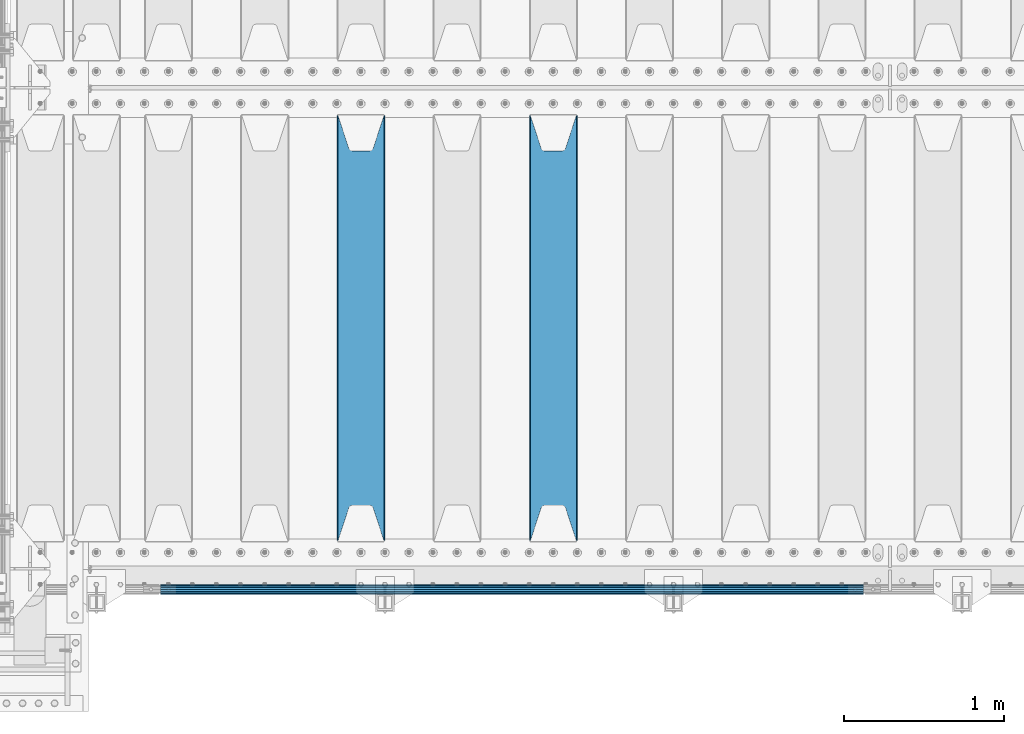
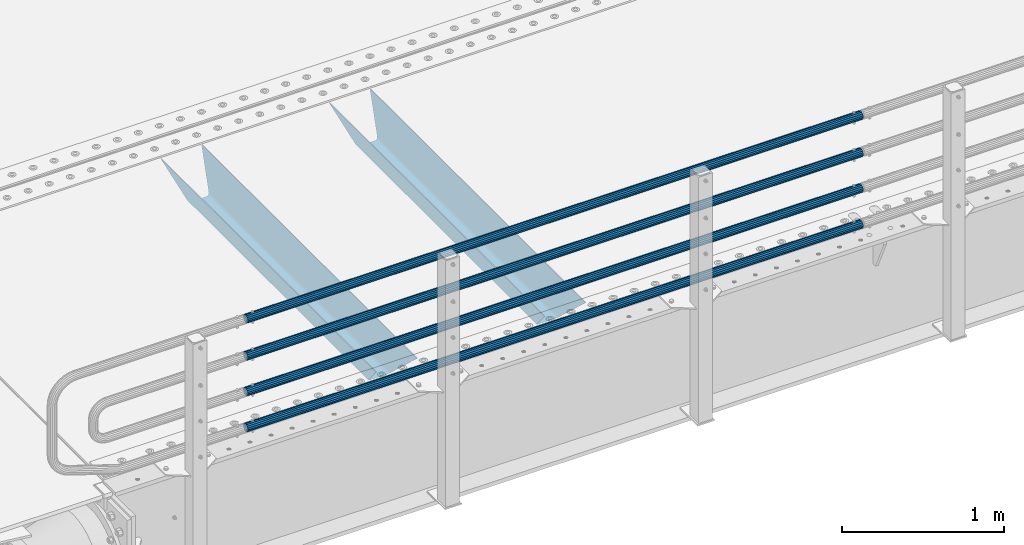
# One storey, part 108 of 247: 6 beams.
"""IFC2X3 building model written with IfcOpenShell, lengths in millimetres."""

from ifc_helpers import new_model, si_unit, frame, origin_with_axes, place, context, subcontext, project, spatial, faceted_brep, material, type_object, element, save


model = new_model("IFC2X3")

# Units and contexts
model_context = context("Model", 3, precision=1e-05, world=origin_with_axes())
body_context = subcontext(model_context, "Body", "Model", "MODEL_VIEW")
ifc_project = project(units=[si_unit("LENGTHUNIT", "METRE", prefix="MILLI"), si_unit("AREAUNIT", "SQUARE_METRE"), si_unit("VOLUMEUNIT", "CUBIC_METRE"), si_unit("MASSUNIT", "GRAM", prefix="KILO"), si_unit("TIMEUNIT", "SECOND"), si_unit("PLANEANGLEUNIT", "RADIAN"), si_unit("SOLIDANGLEUNIT", "STERADIAN"), si_unit("THERMODYNAMICTEMPERATUREUNIT", "DEGREE_CELSIUS"), si_unit("LUMINOUSINTENSITYUNIT", "LUMEN")], contexts=[model_context])

# Site, building, storey
site_placement = place(None, origin_with_axes())
site = spatial("IfcSite", under=ifc_project, at=site_placement, CompositionType="ELEMENT")
building_placement = place(site_placement, origin_with_axes())
building = spatial("IfcBuilding", under=site, at=building_placement, Name="Standard", CompositionType="ELEMENT")
storey_placement = place(building_placement, origin_with_axes())
storey = spatial("IfcBuildingStorey", under=building, at=storey_placement, Name="Undefined", CompositionType="ELEMENT", Elevation=0.0)

# Beams
ifc_material_1 = material(Name="STEEL/S355N")
beam_type_1 = type_object("IfcBeamType", PredefinedType="NOTDEFINED")
beam_1_placement = place(storey_placement, frame((3400.0, 175.0, -115.0), z_axis=(0.0, 0.0, 1.0), x_axis=(0.0, 1.0, 0.0)))
element("IfcBeam", 1, at=beam_1_placement, inside=storey, type_object=beam_type_1, material=ifc_material_1, context=body_context, shape_type="Brep", body=[
    faceted_brep([(0.0, 150.0, 115.0), (0.0, 143.689999999999, 115.0), (2650.00000000297, 143.689999999999, 115.0), (2650.00000000297, 150.0, 115.0), (2650.00000000297, 142.059565218402, 110.0000000031), (2650.00000000297, 148.369565218403, 110.0000000031), (2441.90079219208, -80.1103600731112, -98.0992078077845), (2437.7588105432, -77.5672621345584, -102.241189456673), (2434.06523489746, -74.4080125315522, -105.934765102404), (2430.91086095089, -70.710272125576, -109.089139048974), (2428.37322971128, -66.5649389910068, -111.626770288588), (2426.51472138054, -62.0739139532889, -113.485278619323), (2425.38102192091, -57.3475956567672, -114.618978078955), (2424.99999999987, -52.5021667386536, -115.0), (2424.99999999987, 52.5021667386536, -115.0), (2425.38102192091, 57.3475956567672, -114.618978078955), (2426.51472138054, 62.0739139532889, -113.485278619323), (2428.37322971128, 66.5649389910068, -111.626770288588), (2430.91086095089, 70.710272125576, -109.089139048974), (2434.06523489746, 74.4080125315522, -105.934765102404), (2437.7588105432, 77.5672621345584, -102.241189456673), (2441.90079219208, 80.1103600731112, -98.0992078077846), (2446.38936140511, 81.9747917625791, -93.6106385947584), (2448.24948500409, 76.2713538057251, -91.7505149957729), (2444.62967112262, 74.76777986261, -95.3703288772456), (2441.28936334126, 72.7168944282894, -98.710636658607), (2438.31067330438, 70.1691124903846, -101.689326695487), (2435.76682334747, 67.1870637758839, -104.233176652398), (2433.72034654133, 63.8440531834895, -106.279653458539), (2432.22154950041, 60.222258798236, -107.778450499454), (2431.30727574265, 56.4107117849089, -108.692724257221), (2430.99999999987, 52.5031078186876, -109.0), (2430.99999999987, -52.5031078186876, -109.0), (2431.30727574265, -56.4107117849089, -108.692724257221), (2432.22154950041, -60.222258798236, -107.778450499454), (2433.72034654133, -63.8440531834895, -106.279653458539), (2435.76682334747, -67.1870637758839, -104.233176652398), (2438.31067330438, -70.1691124903846, -101.689326695487), (2441.28936334126, -72.7168944282894, -98.7106366586071), (2444.62967112262, -74.76777986261, -95.3703288772457), (2448.24948500409, -76.2713538057251, -91.7505149957729), (2650.00000000297, -142.059565218402, 110.0000000031), (2650.00000000297, -148.369565218403, 110.0000000031), (2446.38936140511, -81.9747917625791, -93.6106385947584), (2650.00000000297, -143.689999999999, 115.0), (2650.00000000297, -150.0, 115.0), (0.0, -143.689999999999, 115.0), (0.0, -150.0, 115.0), (0.0, -148.369565218261, 110.000000002663), (203.610638597422, -81.9747917625791, -93.6106385947584), (208.099207810448, -80.1103600731112, -98.0992078077845), (212.241189459336, -77.5672621345584, -102.241189456673), (215.934765105068, -74.4080125315522, -105.934765102404), (219.089139051637, -70.710272125576, -109.089139048974), (221.626770291251, -66.5649389910068, -111.626770288588), (223.485278621985, -62.0739139532889, -113.485278619323), (224.618978081617, -57.3475956567672, -114.618978078955), (225.000000002663, -52.5021667386536, -115.0), (225.000000002663, 52.5021667386536, -115.0), (224.618978081617, 57.3475956567672, -114.618978078955), (223.485278621985, 62.0739139532889, -113.485278619323), (221.626770291251, 66.5649389910068, -111.626770288588), (219.089139051637, 70.710272125576, -109.089139048974), (215.934765105068, 74.4080125315522, -105.934765102404), (212.241189459336, 77.5672621345584, -102.241189456673), (208.099207810448, 80.1103600731112, -98.0992078077846), (203.610638597422, 81.9747917625791, -93.6106385947584), (0.0, 148.369565218261, 110.000000002663), (0.0, 142.05956521826, 110.000000002663), (201.750514998436, 76.2713538057251, -91.7505149957729), (205.370328879908, 74.76777986261, -95.3703288772456), (208.710636661271, 72.7168944282894, -98.710636658607), (211.68932669815, 70.1691124903846, -101.689326695487), (214.233176655061, 67.1870637758839, -104.233176652398), (216.279653461202, 63.8440531834895, -106.279653458539), (217.778450502117, 60.222258798236, -107.778450499454), (218.692724259885, 56.4107117849089, -108.692724257221), (219.000000002663, 52.5031078186876, -109.0), (219.000000002663, -52.5031078186876, -109.0), (218.692724259885, -56.4107117849089, -108.692724257221), (217.778450502117, -60.222258798236, -107.778450499454), (216.279653461202, -63.8440531834895, -106.279653458539), (214.233176655061, -67.1870637758839, -104.233176652398), (211.68932669815, -70.1691124903846, -101.689326695487), (208.710636661271, -72.7168944282894, -98.7106366586071), (205.370328879908, -74.76777986261, -95.3703288772457), (201.750514998436, -76.2713538057251, -91.7505149957729), (0.0, -142.05956521826, 110.000000002663)], [[[0, 1, 2, 3]], [[3, 2, 4, 5]], [[6, 7, 8, 9, 10, 11, 12, 13, 14, 15, 16, 17, 18, 19, 20, 21, 22, 5, 4, 23, 24, 25, 26, 27, 28, 29, 30, 31, 32, 33, 34, 35, 36, 37, 38, 39, 40, 41, 42, 43]], [[44, 45, 42, 41]], [[46, 47, 45, 44]], [[43, 42, 45, 47, 48, 49]], [[6, 43, 49, 50]], [[7, 6, 50, 51]], [[8, 7, 51, 52]], [[9, 8, 52, 53]], [[10, 9, 53, 54]], [[11, 10, 54, 55]], [[12, 11, 55, 56]], [[13, 12, 56, 57]], [[14, 13, 57, 58]], [[15, 14, 58, 59]], [[16, 15, 59, 60]], [[17, 16, 60, 61]], [[18, 17, 61, 62]], [[19, 18, 62, 63]], [[20, 19, 63, 64]], [[21, 20, 64, 65]], [[22, 21, 65, 66]], [[0, 3, 5, 22, 66, 67]], [[1, 0, 67, 68]], [[23, 4, 2, 1, 68, 69]], [[24, 23, 69, 70]], [[25, 24, 70, 71]], [[26, 25, 71, 72]], [[27, 26, 72, 73]], [[28, 27, 73, 74]], [[29, 28, 74, 75]], [[30, 29, 75, 76]], [[31, 30, 76, 77]], [[32, 31, 77, 78]], [[33, 32, 78, 79]], [[34, 33, 79, 80]], [[35, 34, 80, 81]], [[36, 35, 81, 82]], [[37, 36, 82, 83]], [[38, 37, 83, 84]], [[39, 38, 84, 85]], [[40, 39, 85, 86]], [[46, 44, 41, 40, 86, 87]], [[47, 46, 87, 48]], [[86, 85, 84, 83, 82, 81, 80, 79, 78, 77, 76, 75, 74, 73, 72, 71, 70, 69, 68, 67, 66, 65, 64, 63, 62, 61, 60, 59, 58, 57, 56, 55, 54, 53, 52, 51, 50, 49, 48, 87]]]),
])
beam_2_placement = place(storey_placement, frame((2200.0, 175.0, -115.0), z_axis=(0.0, 0.0, 1.0), x_axis=(0.0, 1.0, 0.0)))
element("IfcBeam", 2, at=beam_2_placement, inside=storey, type_object=beam_type_1, material=ifc_material_1, context=body_context, shape_type="Brep", body=[
    faceted_brep([(0.0, 150.0, 115.0), (0.0, 143.689999999999, 115.0), (2650.00000000297, 143.689999999999, 115.0), (2650.00000000297, 150.0, 115.0), (2650.00000000297, 142.059565218402, 110.0000000031), (2650.00000000297, 148.369565218403, 110.0000000031), (2441.90079219208, -80.1103600731112, -98.0992078077845), (2437.7588105432, -77.5672621345584, -102.241189456673), (2434.06523489746, -74.4080125315522, -105.934765102404), (2430.91086095089, -70.710272125576, -109.089139048974), (2428.37322971128, -66.5649389910068, -111.626770288588), (2426.51472138054, -62.0739139532889, -113.485278619323), (2425.38102192091, -57.3475956567672, -114.618978078955), (2424.99999999987, -52.5021667386536, -115.0), (2424.99999999987, 52.5021667386536, -115.0), (2425.38102192091, 57.3475956567672, -114.618978078955), (2426.51472138054, 62.0739139532889, -113.485278619323), (2428.37322971128, 66.5649389910068, -111.626770288588), (2430.91086095089, 70.710272125576, -109.089139048974), (2434.06523489746, 74.4080125315522, -105.934765102404), (2437.7588105432, 77.5672621345584, -102.241189456673), (2441.90079219208, 80.1103600731112, -98.0992078077846), (2446.38936140511, 81.9747917625791, -93.6106385947584), (2448.24948500409, 76.2713538057251, -91.7505149957729), (2444.62967112262, 74.76777986261, -95.3703288772456), (2441.28936334126, 72.7168944282894, -98.710636658607), (2438.31067330438, 70.1691124903846, -101.689326695487), (2435.76682334747, 67.1870637758839, -104.233176652398), (2433.72034654133, 63.8440531834895, -106.279653458539), (2432.22154950041, 60.222258798236, -107.778450499454), (2431.30727574265, 56.4107117849089, -108.692724257221), (2430.99999999987, 52.5031078186876, -109.0), (2430.99999999987, -52.5031078186876, -109.0), (2431.30727574265, -56.4107117849089, -108.692724257221), (2432.22154950041, -60.222258798236, -107.778450499454), (2433.72034654133, -63.8440531834895, -106.279653458539), (2435.76682334747, -67.1870637758839, -104.233176652398), (2438.31067330438, -70.1691124903846, -101.689326695487), (2441.28936334126, -72.7168944282894, -98.7106366586071), (2444.62967112262, -74.76777986261, -95.3703288772457), (2448.24948500409, -76.2713538057251, -91.7505149957729), (2650.00000000297, -142.059565218402, 110.0000000031), (2650.00000000297, -148.369565218403, 110.0000000031), (2446.38936140511, -81.9747917625791, -93.6106385947584), (2650.00000000297, -143.689999999999, 115.0), (2650.00000000297, -150.0, 115.0), (0.0, -143.689999999999, 115.0), (0.0, -150.0, 115.0), (0.0, -148.369565218261, 110.000000002663), (203.610638597422, -81.9747917625791, -93.6106385947584), (208.099207810448, -80.1103600731112, -98.0992078077845), (212.241189459336, -77.5672621345584, -102.241189456673), (215.934765105068, -74.4080125315522, -105.934765102404), (219.089139051637, -70.710272125576, -109.089139048974), (221.626770291251, -66.5649389910068, -111.626770288588), (223.485278621985, -62.0739139532889, -113.485278619323), (224.618978081617, -57.3475956567672, -114.618978078955), (225.000000002663, -52.5021667386536, -115.0), (225.000000002663, 52.5021667386536, -115.0), (224.618978081617, 57.3475956567672, -114.618978078955), (223.485278621985, 62.0739139532889, -113.485278619323), (221.626770291251, 66.5649389910068, -111.626770288588), (219.089139051637, 70.710272125576, -109.089139048974), (215.934765105068, 74.4080125315522, -105.934765102404), (212.241189459336, 77.5672621345584, -102.241189456673), (208.099207810448, 80.1103600731112, -98.0992078077846), (203.610638597422, 81.9747917625791, -93.6106385947584), (0.0, 148.369565218261, 110.000000002663), (0.0, 142.05956521826, 110.000000002663), (201.750514998436, 76.2713538057251, -91.7505149957729), (205.370328879908, 74.76777986261, -95.3703288772456), (208.710636661271, 72.7168944282894, -98.710636658607), (211.68932669815, 70.1691124903846, -101.689326695487), (214.233176655061, 67.1870637758839, -104.233176652398), (216.279653461202, 63.8440531834895, -106.279653458539), (217.778450502117, 60.222258798236, -107.778450499454), (218.692724259885, 56.4107117849089, -108.692724257221), (219.000000002663, 52.5031078186876, -109.0), (219.000000002663, -52.5031078186876, -109.0), (218.692724259885, -56.4107117849089, -108.692724257221), (217.778450502117, -60.222258798236, -107.778450499454), (216.279653461202, -63.8440531834895, -106.279653458539), (214.233176655061, -67.1870637758839, -104.233176652398), (211.68932669815, -70.1691124903846, -101.689326695487), (208.710636661271, -72.7168944282894, -98.7106366586071), (205.370328879908, -74.76777986261, -95.3703288772457), (201.750514998436, -76.2713538057251, -91.7505149957729), (0.0, -142.05956521826, 110.000000002663)], [[[0, 1, 2, 3]], [[3, 2, 4, 5]], [[6, 7, 8, 9, 10, 11, 12, 13, 14, 15, 16, 17, 18, 19, 20, 21, 22, 5, 4, 23, 24, 25, 26, 27, 28, 29, 30, 31, 32, 33, 34, 35, 36, 37, 38, 39, 40, 41, 42, 43]], [[44, 45, 42, 41]], [[46, 47, 45, 44]], [[43, 42, 45, 47, 48, 49]], [[6, 43, 49, 50]], [[7, 6, 50, 51]], [[8, 7, 51, 52]], [[9, 8, 52, 53]], [[10, 9, 53, 54]], [[11, 10, 54, 55]], [[12, 11, 55, 56]], [[13, 12, 56, 57]], [[14, 13, 57, 58]], [[15, 14, 58, 59]], [[16, 15, 59, 60]], [[17, 16, 60, 61]], [[18, 17, 61, 62]], [[19, 18, 62, 63]], [[20, 19, 63, 64]], [[21, 20, 64, 65]], [[22, 21, 65, 66]], [[0, 3, 5, 22, 66, 67]], [[1, 0, 67, 68]], [[23, 4, 2, 1, 68, 69]], [[24, 23, 69, 70]], [[25, 24, 70, 71]], [[26, 25, 71, 72]], [[27, 26, 72, 73]], [[28, 27, 73, 74]], [[29, 28, 74, 75]], [[30, 29, 75, 76]], [[31, 30, 76, 77]], [[32, 31, 77, 78]], [[33, 32, 78, 79]], [[34, 33, 79, 80]], [[35, 34, 80, 81]], [[36, 35, 81, 82]], [[37, 36, 82, 83]], [[38, 37, 83, 84]], [[39, 38, 84, 85]], [[40, 39, 85, 86]], [[46, 44, 41, 40, 86, 87]], [[47, 46, 87, 48]], [[86, 85, 84, 83, 82, 81, 80, 79, 78, 77, 76, 75, 74, 73, 72, 71, 70, 69, 68, 67, 66, 65, 64, 63, 62, 61, 60, 59, 58, 57, 56, 55, 54, 53, 52, 51, 50, 49, 48, 87]]]),
])
ifc_material_2 = material()
beam_type_2 = type_object("IfcBeamType", PredefinedType="NOTDEFINED")
beam_3_placement = place(storey_placement, frame((5333.99999999987, -129.849999999907, 149.849999999725), z_axis=(0.0, 0.0, -1.0), x_axis=(-1.0, 0.0, 0.0)))
element("IfcBeam", 3, at=beam_3_placement, inside=storey, type_object=beam_type_2, material=ifc_material_2, context=body_context, shape_type="Brep", body=[
    faceted_brep([(0.0, -26.5499999999993, 0.0), (0.0, -24.5290015881747, 10.1602451292931), (4384.00249699992, -24.5290015881747, 10.1602451292931), (4384.00249699992, -26.5499999999993, 0.0), (0.0, -18.7736850405036, 18.7736850405028), (4384.00249699992, -18.7736850405036, 18.7736850405028), (0.0, -10.1602451292929, 24.5290015881747), (4384.00249699992, -10.1602451292929, 24.5290015881747), (0.0, 0.0, 26.55), (4384.00249699992, 0.0, 26.55), (0.0, 10.1602451292929, 24.5290015881747), (4384.00249699992, 10.1602451292929, 24.5290015881747), (0.0, 18.7736850405036, 18.7736850405028), (4384.00249699992, 18.7736850405036, 18.7736850405028), (0.0, 24.5290015881747, 10.1602451292931), (4384.00249699992, 24.5290015881747, 10.1602451292931), (0.0, 26.5499999999993, 0.0), (4384.00249699992, 26.5499999999993, 0.0), (0.0, 24.5290015881747, -10.1602451292931), (4384.00249699992, 24.5290015881747, -10.1602451292931), (0.0, 18.7736850405036, -18.7736850405028), (4384.00249699992, 18.7736850405036, -18.7736850405028), (0.0, 10.1602451292929, -24.5290015881747), (4384.00249699992, 10.1602451292929, -24.5290015881747), (0.0, 0.0, -26.55), (4384.00249699992, 0.0, -26.55), (0.0, -10.1602451292929, -24.5290015881747), (4384.00249699992, -10.1602451292929, -24.5290015881747), (0.0, -18.7736850405036, -18.7736850405028), (4384.00249699992, -18.7736850405036, -18.7736850405028), (0.0, -24.5290015881747, -10.1602451292931), (4384.00249699992, -24.5290015881747, -10.1602451292931), (0.0, -30.1499999999996, 0.0), (0.0, -27.8549679052148, -11.5379054858076), (4384.00249699992, -27.8549679052157, -11.5379054858075), (4384.00249699992, -30.1499999999996, 0.0), (0.0, -21.3192694527743, -21.3192694527752), (4384.00249699992, -21.3192694527752, -21.3192694527744), (0.0, -11.5379054858076, -27.8549679052157), (4384.00249699992, -11.5379054858076, -27.8549679052153), (0.0, 0.0, -30.1499999999996), (4384.00249699992, 0.0, -30.15), (0.0, 11.5379054858076, -27.8549679052157), (4384.00249699992, 11.5379054858076, -27.8549679052153), (0.0, 21.3192694527743, -21.3192694527752), (4384.00249699992, 21.3192694527752, -21.3192694527744), (0.0, 27.8549679052157, -11.5379054858076), (4384.00249699992, 27.8549679052157, -11.5379054858074), (0.0, 30.1499999999996, 0.0), (4384.00249699992, 30.1499999999996, 0.0), (0.0, 27.8549679052157, 11.5379054858076), (4384.00249699992, 27.8549679052157, 11.5379054858075), (0.0, 21.3192694527743, 21.3192694527752), (4384.00249699992, 21.3192694527752, 21.3192694527744), (0.0, 11.5379054858076, 27.8549679052157), (4384.00249699992, 11.5379054858076, 27.8549679052153), (0.0, 0.0, 30.1499999999996), (4384.00249699992, 0.0, 30.15), (0.0, -11.5379054858076, 27.8549679052157), (4384.00249699992, -11.5379054858076, 27.8549679052153), (0.0, -21.3192694527743, 21.3192694527752), (4384.00249699992, -21.3192694527752, 21.3192694527744), (0.0, -27.8549679052157, 11.5379054858076), (4384.00249699992, -27.8549679052157, 11.5379054858075)], [[[0, 1, 2, 3]], [[1, 4, 5, 2]], [[4, 6, 7, 5]], [[6, 8, 9, 7]], [[8, 10, 11, 9]], [[10, 12, 13, 11]], [[12, 14, 15, 13]], [[14, 16, 17, 15]], [[16, 18, 19, 17]], [[18, 20, 21, 19]], [[20, 22, 23, 21]], [[22, 24, 25, 23]], [[24, 26, 27, 25]], [[26, 28, 29, 27]], [[28, 30, 31, 29]], [[30, 0, 3, 31]], [[32, 33, 34, 35]], [[33, 36, 37, 34]], [[36, 38, 39, 37]], [[38, 40, 41, 39]], [[40, 42, 43, 41]], [[42, 44, 45, 43]], [[44, 46, 47, 45]], [[46, 48, 49, 47]], [[48, 50, 51, 49]], [[50, 52, 53, 51]], [[52, 54, 55, 53]], [[54, 56, 57, 55]], [[56, 58, 59, 57]], [[58, 60, 61, 59]], [[60, 62, 63, 61]], [[62, 32, 35, 63]], [[37, 39, 41, 43, 45, 47, 49, 51, 53, 55, 57, 59, 61, 63, 35, 34], [5, 7, 9, 11, 13, 15, 17, 19, 21, 23, 25, 27, 29, 31, 3, 2]], [[62, 60, 58, 56, 54, 52, 50, 48, 46, 44, 42, 40, 38, 36, 33, 32], [30, 28, 26, 24, 22, 20, 18, 16, 14, 12, 10, 8, 6, 4, 1, 0]]]),
])
beam_4_placement = place(storey_placement, frame((5333.99999999987, -129.849999999907, 420.149999999728), z_axis=(0.0, 0.0, -1.0), x_axis=(-1.0, 0.0, 0.0)))
element("IfcBeam", 4, at=beam_4_placement, inside=storey, type_object=beam_type_2, material=ifc_material_2, context=body_context, shape_type="Brep", body=[
    faceted_brep([(0.0, -26.5499999999993, 0.0), (0.0, -24.5290015881747, 10.1602451292931), (4384.00249699992, -24.5290015881747, 10.1602451292931), (4384.00249699992, -26.5499999999993, 0.0), (0.0, -18.7736850405036, 18.7736850405028), (4384.00249699992, -18.7736850405036, 18.7736850405028), (0.0, -10.1602451292929, 24.5290015881747), (4384.00249699992, -10.1602451292929, 24.5290015881747), (0.0, 0.0, 26.55), (4384.00249699992, 0.0, 26.55), (0.0, 10.1602451292929, 24.5290015881747), (4384.00249699992, 10.1602451292929, 24.5290015881747), (0.0, 18.7736850405036, 18.7736850405028), (4384.00249699992, 18.7736850405036, 18.7736850405028), (0.0, 24.5290015881747, 10.1602451292931), (4384.00249699992, 24.5290015881747, 10.1602451292931), (0.0, 26.5499999999993, 0.0), (4384.00249699992, 26.5499999999993, 0.0), (0.0, 24.5290015881747, -10.1602451292931), (4384.00249699992, 24.5290015881747, -10.1602451292931), (0.0, 18.7736850405036, -18.7736850405028), (4384.00249699992, 18.7736850405036, -18.7736850405028), (0.0, 10.1602451292929, -24.5290015881747), (4384.00249699992, 10.1602451292929, -24.5290015881747), (0.0, 0.0, -26.55), (4384.00249699992, 0.0, -26.55), (0.0, -10.1602451292929, -24.5290015881747), (4384.00249699992, -10.1602451292929, -24.5290015881747), (0.0, -18.7736850405036, -18.7736850405028), (4384.00249699992, -18.7736850405036, -18.7736850405028), (0.0, -24.5290015881747, -10.1602451292931), (4384.00249699992, -24.5290015881747, -10.1602451292931), (0.0, -30.1499999999996, 0.0), (0.0, -27.8549679052148, -11.5379054858076), (4384.00249699992, -27.8549679052157, -11.5379054858075), (4384.00249699992, -30.1499999999996, 0.0), (0.0, -21.3192694527743, -21.3192694527752), (4384.00249699992, -21.3192694527752, -21.3192694527744), (0.0, -11.5379054858076, -27.8549679052157), (4384.00249699992, -11.5379054858076, -27.8549679052153), (0.0, 0.0, -30.1499999999996), (4384.00249699992, 0.0, -30.15), (0.0, 11.5379054858076, -27.8549679052157), (4384.00249699992, 11.5379054858076, -27.8549679052153), (0.0, 21.3192694527743, -21.3192694527752), (4384.00249699992, 21.3192694527752, -21.3192694527744), (0.0, 27.8549679052157, -11.5379054858076), (4384.00249699992, 27.8549679052157, -11.5379054858074), (0.0, 30.1499999999996, 0.0), (4384.00249699992, 30.1499999999996, 0.0), (0.0, 27.8549679052157, 11.5379054858076), (4384.00249699992, 27.8549679052157, 11.5379054858075), (0.0, 21.3192694527743, 21.3192694527752), (4384.00249699992, 21.3192694527752, 21.3192694527744), (0.0, 11.5379054858076, 27.8549679052157), (4384.00249699992, 11.5379054858076, 27.8549679052153), (0.0, 0.0, 30.1499999999996), (4384.00249699992, 0.0, 30.15), (0.0, -11.5379054858076, 27.8549679052157), (4384.00249699992, -11.5379054858076, 27.8549679052153), (0.0, -21.3192694527743, 21.3192694527752), (4384.00249699992, -21.3192694527752, 21.3192694527744), (0.0, -27.8549679052157, 11.5379054858076), (4384.00249699992, -27.8549679052157, 11.5379054858075)], [[[0, 1, 2, 3]], [[1, 4, 5, 2]], [[4, 6, 7, 5]], [[6, 8, 9, 7]], [[8, 10, 11, 9]], [[10, 12, 13, 11]], [[12, 14, 15, 13]], [[14, 16, 17, 15]], [[16, 18, 19, 17]], [[18, 20, 21, 19]], [[20, 22, 23, 21]], [[22, 24, 25, 23]], [[24, 26, 27, 25]], [[26, 28, 29, 27]], [[28, 30, 31, 29]], [[30, 0, 3, 31]], [[32, 33, 34, 35]], [[33, 36, 37, 34]], [[36, 38, 39, 37]], [[38, 40, 41, 39]], [[40, 42, 43, 41]], [[42, 44, 45, 43]], [[44, 46, 47, 45]], [[46, 48, 49, 47]], [[48, 50, 51, 49]], [[50, 52, 53, 51]], [[52, 54, 55, 53]], [[54, 56, 57, 55]], [[56, 58, 59, 57]], [[58, 60, 61, 59]], [[60, 62, 63, 61]], [[62, 32, 35, 63]], [[37, 39, 41, 43, 45, 47, 49, 51, 53, 55, 57, 59, 61, 63, 35, 34], [5, 7, 9, 11, 13, 15, 17, 19, 21, 23, 25, 27, 29, 31, 3, 2]], [[62, 60, 58, 56, 54, 52, 50, 48, 46, 44, 42, 40, 38, 36, 33, 32], [30, 28, 26, 24, 22, 20, 18, 16, 14, 12, 10, 8, 6, 4, 1, 0]]]),
])
beam_5_placement = place(storey_placement, frame((5333.99999999987, -129.849999999907, 969.849999999725), z_axis=(0.0, 0.0, -1.0), x_axis=(-1.0, 0.0, 0.0)))
element("IfcBeam", 5, at=beam_5_placement, inside=storey, type_object=beam_type_2, material=ifc_material_2, context=body_context, shape_type="Brep", body=[
    faceted_brep([(0.0, -26.5499999999993, 0.0), (0.0, -24.5290015881747, 10.1602451292931), (4384.00249699992, -24.5290015881747, 10.1602451292931), (4384.00249699992, -26.5499999999993, 0.0), (0.0, -18.7736850405036, 18.7736850405028), (4384.00249699992, -18.7736850405036, 18.7736850405028), (0.0, -10.1602451292929, 24.5290015881747), (4384.00249699992, -10.1602451292929, 24.5290015881747), (0.0, 0.0, 26.55), (4384.00249699992, 0.0, 26.55), (0.0, 10.1602451292929, 24.5290015881747), (4384.00249699992, 10.1602451292929, 24.5290015881747), (0.0, 18.7736850405036, 18.7736850405028), (4384.00249699992, 18.7736850405036, 18.7736850405028), (0.0, 24.5290015881747, 10.1602451292931), (4384.00249699992, 24.5290015881747, 10.1602451292931), (0.0, 26.5499999999993, 0.0), (4384.00249699992, 26.5499999999993, 0.0), (0.0, 24.5290015881747, -10.1602451292931), (4384.00249699992, 24.5290015881747, -10.1602451292931), (0.0, 18.7736850405036, -18.7736850405028), (4384.00249699992, 18.7736850405036, -18.7736850405028), (0.0, 10.1602451292929, -24.5290015881747), (4384.00249699992, 10.1602451292929, -24.5290015881747), (0.0, 0.0, -26.55), (4384.00249699992, 0.0, -26.55), (0.0, -10.1602451292929, -24.5290015881747), (4384.00249699992, -10.1602451292929, -24.5290015881747), (0.0, -18.7736850405036, -18.7736850405028), (4384.00249699992, -18.7736850405036, -18.7736850405028), (0.0, -24.5290015881747, -10.1602451292931), (4384.00249699992, -24.5290015881747, -10.1602451292931), (0.0, -30.1499999999996, 0.0), (0.0, -27.8549679052148, -11.5379054858076), (4384.00249699992, -27.8549679052157, -11.5379054858075), (4384.00249699992, -30.1499999999996, 0.0), (0.0, -21.3192694527743, -21.3192694527752), (4384.00249699992, -21.3192694527752, -21.3192694527744), (0.0, -11.5379054858076, -27.8549679052157), (4384.00249699992, -11.5379054858076, -27.8549679052153), (0.0, 0.0, -30.1499999999996), (4384.00249699992, 0.0, -30.15), (0.0, 11.5379054858076, -27.8549679052157), (4384.00249699992, 11.5379054858076, -27.8549679052153), (0.0, 21.3192694527743, -21.3192694527752), (4384.00249699992, 21.3192694527752, -21.3192694527744), (0.0, 27.8549679052157, -11.5379054858076), (4384.00249699992, 27.8549679052157, -11.5379054858074), (0.0, 30.1499999999996, 0.0), (4384.00249699992, 30.1499999999996, 0.0), (0.0, 27.8549679052157, 11.5379054858076), (4384.00249699992, 27.8549679052157, 11.5379054858075), (0.0, 21.3192694527743, 21.3192694527752), (4384.00249699992, 21.3192694527752, 21.3192694527744), (0.0, 11.5379054858076, 27.8549679052157), (4384.00249699992, 11.5379054858076, 27.8549679052153), (0.0, 0.0, 30.1499999999996), (4384.00249699992, 0.0, 30.15), (0.0, -11.5379054858076, 27.8549679052157), (4384.00249699992, -11.5379054858076, 27.8549679052153), (0.0, -21.3192694527743, 21.3192694527752), (4384.00249699992, -21.3192694527752, 21.3192694527744), (0.0, -27.8549679052157, 11.5379054858076), (4384.00249699992, -27.8549679052157, 11.5379054858075)], [[[0, 1, 2, 3]], [[1, 4, 5, 2]], [[4, 6, 7, 5]], [[6, 8, 9, 7]], [[8, 10, 11, 9]], [[10, 12, 13, 11]], [[12, 14, 15, 13]], [[14, 16, 17, 15]], [[16, 18, 19, 17]], [[18, 20, 21, 19]], [[20, 22, 23, 21]], [[22, 24, 25, 23]], [[24, 26, 27, 25]], [[26, 28, 29, 27]], [[28, 30, 31, 29]], [[30, 0, 3, 31]], [[32, 33, 34, 35]], [[33, 36, 37, 34]], [[36, 38, 39, 37]], [[38, 40, 41, 39]], [[40, 42, 43, 41]], [[42, 44, 45, 43]], [[44, 46, 47, 45]], [[46, 48, 49, 47]], [[48, 50, 51, 49]], [[50, 52, 53, 51]], [[52, 54, 55, 53]], [[54, 56, 57, 55]], [[56, 58, 59, 57]], [[58, 60, 61, 59]], [[60, 62, 63, 61]], [[62, 32, 35, 63]], [[37, 39, 41, 43, 45, 47, 49, 51, 53, 55, 57, 59, 61, 63, 35, 34], [5, 7, 9, 11, 13, 15, 17, 19, 21, 23, 25, 27, 29, 31, 3, 2]], [[62, 60, 58, 56, 54, 52, 50, 48, 46, 44, 42, 40, 38, 36, 33, 32], [30, 28, 26, 24, 22, 20, 18, 16, 14, 12, 10, 8, 6, 4, 1, 0]]]),
])
beam_6_placement = place(storey_placement, frame((5333.99999999987, -129.849999999907, 689.849999999725), z_axis=(0.0, 0.0, -1.0), x_axis=(-1.0, 0.0, 0.0)))
element("IfcBeam", 6, at=beam_6_placement, inside=storey, type_object=beam_type_2, material=ifc_material_2, context=body_context, shape_type="Brep", body=[
    faceted_brep([(0.0, -26.5499999999993, 0.0), (0.0, -24.5290015881747, 10.1602451292931), (4384.00249699992, -24.5290015881747, 10.1602451292931), (4384.00249699992, -26.5499999999993, 0.0), (0.0, -18.7736850405036, 18.7736850405028), (4384.00249699992, -18.7736850405036, 18.7736850405028), (0.0, -10.1602451292929, 24.5290015881747), (4384.00249699992, -10.1602451292929, 24.5290015881747), (0.0, 0.0, 26.55), (4384.00249699992, 0.0, 26.55), (0.0, 10.1602451292929, 24.5290015881747), (4384.00249699992, 10.1602451292929, 24.5290015881747), (0.0, 18.7736850405036, 18.7736850405028), (4384.00249699992, 18.7736850405036, 18.7736850405028), (0.0, 24.5290015881747, 10.1602451292931), (4384.00249699992, 24.5290015881747, 10.1602451292931), (0.0, 26.5499999999993, 0.0), (4384.00249699992, 26.5499999999993, 0.0), (0.0, 24.5290015881747, -10.1602451292931), (4384.00249699992, 24.5290015881747, -10.1602451292931), (0.0, 18.7736850405036, -18.7736850405028), (4384.00249699992, 18.7736850405036, -18.7736850405028), (0.0, 10.1602451292929, -24.5290015881747), (4384.00249699992, 10.1602451292929, -24.5290015881747), (0.0, 0.0, -26.55), (4384.00249699992, 0.0, -26.55), (0.0, -10.1602451292929, -24.5290015881747), (4384.00249699992, -10.1602451292929, -24.5290015881747), (0.0, -18.7736850405036, -18.7736850405028), (4384.00249699992, -18.7736850405036, -18.7736850405028), (0.0, -24.5290015881747, -10.1602451292931), (4384.00249699992, -24.5290015881747, -10.1602451292931), (0.0, -30.1499999999996, 0.0), (0.0, -27.8549679052148, -11.5379054858076), (4384.00249699992, -27.8549679052157, -11.5379054858075), (4384.00249699992, -30.1499999999996, 0.0), (0.0, -21.3192694527743, -21.3192694527752), (4384.00249699992, -21.3192694527752, -21.3192694527744), (0.0, -11.5379054858076, -27.8549679052157), (4384.00249699992, -11.5379054858076, -27.8549679052153), (0.0, 0.0, -30.1499999999996), (4384.00249699992, 0.0, -30.15), (0.0, 11.5379054858076, -27.8549679052157), (4384.00249699992, 11.5379054858076, -27.8549679052153), (0.0, 21.3192694527743, -21.3192694527752), (4384.00249699992, 21.3192694527752, -21.3192694527744), (0.0, 27.8549679052157, -11.5379054858076), (4384.00249699992, 27.8549679052157, -11.5379054858074), (0.0, 30.1499999999996, 0.0), (4384.00249699992, 30.1499999999996, 0.0), (0.0, 27.8549679052157, 11.5379054858076), (4384.00249699992, 27.8549679052157, 11.5379054858075), (0.0, 21.3192694527743, 21.3192694527752), (4384.00249699992, 21.3192694527752, 21.3192694527744), (0.0, 11.5379054858076, 27.8549679052157), (4384.00249699992, 11.5379054858076, 27.8549679052153), (0.0, 0.0, 30.1499999999996), (4384.00249699992, 0.0, 30.15), (0.0, -11.5379054858076, 27.8549679052157), (4384.00249699992, -11.5379054858076, 27.8549679052153), (0.0, -21.3192694527743, 21.3192694527752), (4384.00249699992, -21.3192694527752, 21.3192694527744), (0.0, -27.8549679052157, 11.5379054858076), (4384.00249699992, -27.8549679052157, 11.5379054858075)], [[[0, 1, 2, 3]], [[1, 4, 5, 2]], [[4, 6, 7, 5]], [[6, 8, 9, 7]], [[8, 10, 11, 9]], [[10, 12, 13, 11]], [[12, 14, 15, 13]], [[14, 16, 17, 15]], [[16, 18, 19, 17]], [[18, 20, 21, 19]], [[20, 22, 23, 21]], [[22, 24, 25, 23]], [[24, 26, 27, 25]], [[26, 28, 29, 27]], [[28, 30, 31, 29]], [[30, 0, 3, 31]], [[32, 33, 34, 35]], [[33, 36, 37, 34]], [[36, 38, 39, 37]], [[38, 40, 41, 39]], [[40, 42, 43, 41]], [[42, 44, 45, 43]], [[44, 46, 47, 45]], [[46, 48, 49, 47]], [[48, 50, 51, 49]], [[50, 52, 53, 51]], [[52, 54, 55, 53]], [[54, 56, 57, 55]], [[56, 58, 59, 57]], [[58, 60, 61, 59]], [[60, 62, 63, 61]], [[62, 32, 35, 63]], [[37, 39, 41, 43, 45, 47, 49, 51, 53, 55, 57, 59, 61, 63, 35, 34], [5, 7, 9, 11, 13, 15, 17, 19, 21, 23, 25, 27, 29, 31, 3, 2]], [[62, 60, 58, 56, 54, 52, 50, 48, 46, 44, 42, 40, 38, 36, 33, 32], [30, 28, 26, 24, 22, 20, 18, 16, 14, 12, 10, 8, 6, 4, 1, 0]]]),
])

save(model, "model.ifc")
